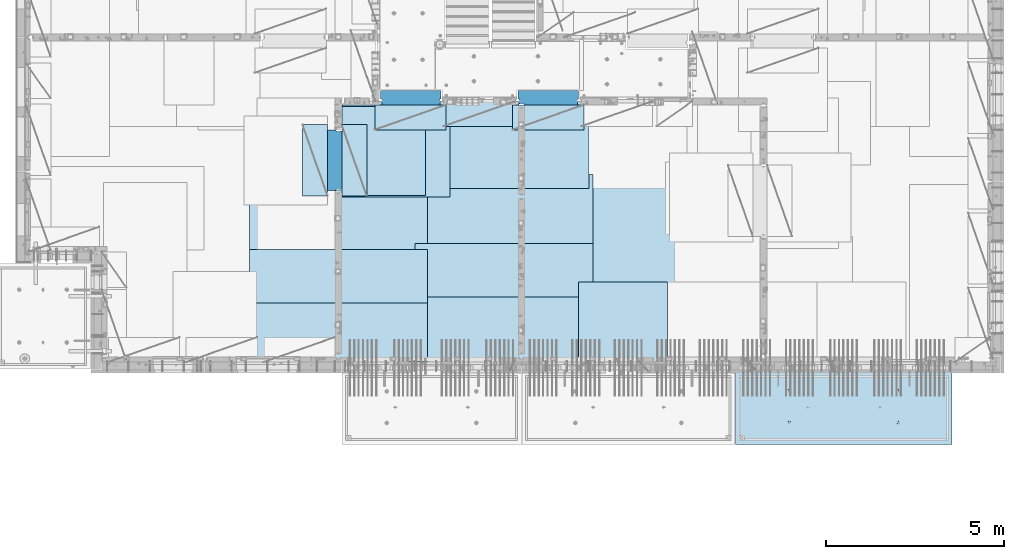
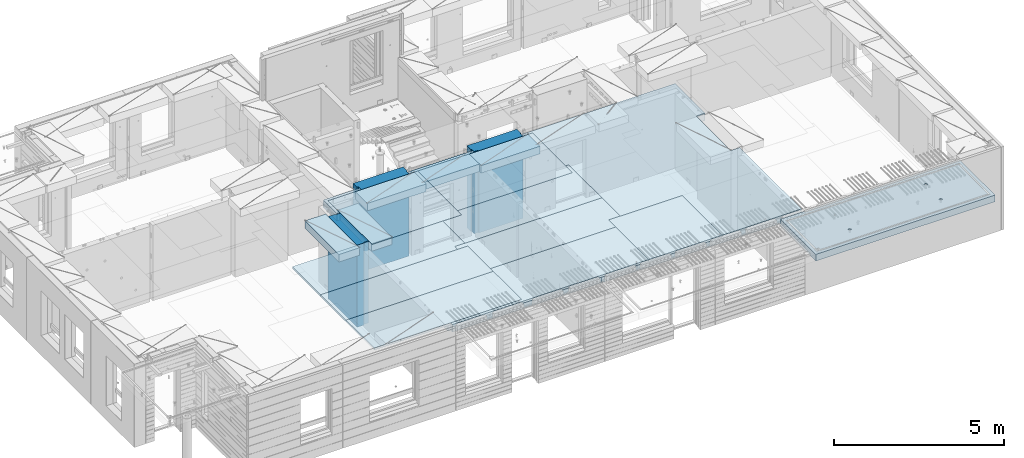
# One storey, part 203 of 349: 18 plates, 3 slabs, 19 elements without a shape of their own.
"""IFC2X3 building model written with IfcOpenShell, lengths in millimetres."""

from ifc_helpers import new_model, si_unit, frame, origin_with_axes, place, context, subcontext, project, spatial, faceted_brep, material, type_object, element, aggregate, save


model = new_model("IFC2X3")

# Units and contexts
model_context = context("Model", 3, precision=1e-05, world=origin_with_axes())
body_context = subcontext(model_context, "Body", "Model", "MODEL_VIEW")
ifc_project = project(units=[si_unit("LENGTHUNIT", "METRE", prefix="MILLI"), si_unit("AREAUNIT", "SQUARE_METRE"), si_unit("VOLUMEUNIT", "CUBIC_METRE"), si_unit("MASSUNIT", "GRAM", prefix="KILO"), si_unit("TIMEUNIT", "SECOND"), si_unit("PLANEANGLEUNIT", "RADIAN"), si_unit("SOLIDANGLEUNIT", "STERADIAN"), si_unit("THERMODYNAMICTEMPERATUREUNIT", "DEGREE_CELSIUS"), si_unit("LUMINOUSINTENSITYUNIT", "LUMEN")], contexts=[model_context])

# Site, building, storey
site_placement = place(None, origin_with_axes())
site = spatial("IfcSite", under=ifc_project, at=site_placement, CompositionType="ELEMENT")
building_placement = place(site_placement, origin_with_axes())
building = spatial("IfcBuilding", under=site, at=building_placement, CompositionType="ELEMENT")
storey_placement = place(building_placement, origin_with_axes())
storey = spatial("IfcBuildingStorey", under=building, at=storey_placement, Name="4", CompositionType="ELEMENT", Elevation=0.0)

# Assembly, slab
assembly_1_placement = place(storey_placement, origin_with_axes())
assembly_1 = element("IfcElementAssembly", 1, at=assembly_1_placement, inside=storey, AssemblyPlace="NOTDEFINED", PredefinedType="REINFORCEMENT_UNIT")
ifc_material_1 = material(Name="CONCRETE/C30/37")
slab_type_1 = type_object("IfcSlabType", PredefinedType="NOTDEFINED")
slab_1_placement = place(assembly_1_placement, frame((21810.0, 7750.0, 93595.0), z_axis=(0.0, 1.0, 0.0), x_axis=(1.0, 0.0, 0.0)))
slab_1 = element("IfcSlab", 2, at=slab_1_placement, type_object=slab_type_1, material=ifc_material_1, PredefinedType="FLOOR", context=body_context, shape_type="Brep", body=[
    faceted_brep([(6500.0, -135.0, 5637.99963378906), (6500.0, 135.0, 5637.99963378906), (6500.0, 135.0, 5680.0), (6500.0, -135.0, 5680.0), (6800.0, -135.0, 5680.0), (6800.0, 135.0, 5680.0), (6800.0, -135.0, 3637.99963378906), (6800.0, 135.0, 3637.99963378906), (6500.0, 135.0, 3637.99963378906), (6500.0, -135.0, 3637.99963378906), (6800.0, -135.0, 0.0), (6800.0, 135.0, 0.0), (1.81898940354586e-12, -135.0, 1.81898940354586e-12), (1.81898940354586e-12, 135.0, 1.81898940354586e-12), (0.0, -135.0, 7330.0), (0.0, 135.0, 7330.0), (1569.99914550782, -135.0, 7330.0), (1569.99914550782, 135.0, 7330.0), (1569.99914550782, -135.0, 7430.0), (1569.99914550782, 135.0, 7430.0), (6800.0, -135.0, 7430.0), (6800.0, 135.0, 7430.0), (6500.0, 135.0, 3780.0), (6500.0, -135.0, 3780.0)], [[[0, 1, 2, 3]], [[4, 3, 2, 5]], [[6, 7, 8, 9]], [[10, 11, 7, 6]], [[10, 12, 13, 11]], [[12, 14, 15, 13]], [[16, 17, 15, 14]], [[18, 19, 17, 16]], [[20, 21, 19, 18]], [[21, 20, 4, 5]], [[1, 22, 8, 7, 11, 13, 15, 17, 19, 21, 5, 2]], [[23, 9, 8, 22, 1, 0]], [[20, 18, 16, 14, 12, 10, 6, 9, 23, 0, 3, 4]]]),
])

assembly_2_placement = place(storey_placement, origin_with_axes())
assembly_2 = element("IfcElementAssembly", 3, at=assembly_2_placement, inside=storey, AssemblyPlace="NOTDEFINED", PredefinedType="REINFORCEMENT_UNIT")
ifc_material_2 = material(Name="CONCRETE/C35/45")
slab_type_2 = type_object("IfcSlabType", PredefinedType="NOTDEFINED")
slab_2_placement = place(assembly_2_placement, frame((33909.9998568133, 7629.99655735226, 93590.0), z_axis=(-1.11800000013248e-06, -0.999999999999375, 0.0), x_axis=(-0.999999999999093, 1.34699999998405e-06, 0.0)))
slab_2 = element("IfcSlab", 4, at=slab_2_placement, type_object=slab_type_2, material=ifc_material_2, PredefinedType="FLOOR", context=body_context, shape_type="Brep", body=[
    faceted_brep([(4605.44993885855, -113.0, 552.448239707288), (4619.38834372919, -113.0, 559.550231553701), (4630.44991833371, -113.0, 570.61183115741), (4637.55187867931, -113.0, 584.55025207851), (4639.99903540509, -113.0, 600.001104562554), (4637.55184376039, -113.0, 615.451951515985), (4630.44985191398, -113.0, 629.39035638662), (4619.38825231027, -113.0, 640.451930991143), (4605.44983138917, -113.0, 647.553891336743), (4589.99897890513, -113.0, 650.001048062522), (4574.54813195169, -113.0, 647.553856417822), (4560.60972708106, -113.0, 640.451864571409), (4549.54815247653, -113.0, 629.390264967699), (4542.44619213093, -113.0, 615.451844046599), (4539.99903540516, -113.0, 600.000991562554), (4542.44622704986, -113.0, 584.550144609124), (4549.54821889627, -113.0, 570.61173973849), (4560.60981849998, -113.0, 559.550165133966), (4574.54823942108, -113.0, 552.448204788368), (4589.99909190512, -113.0, 550.001048062586), (4548.90468317908, -120.0, 570.144182560607), (4541.68970509875, -120.0, 584.304334781456), (4560.14226277649, -120.0, 558.906628360102), (4574.30243130315, -120.0, 551.691682281732), (4589.99909280399, -120.0, 549.205593517132), (4605.69574868622, -120.0, 551.691717756181), (4619.85590090707, -120.0, 558.906695836513), (4631.09345510757, -120.0, 570.14427543392), (4638.30840118594, -120.0, 584.304443960583), (4640.79448995055, -120.0, 600.001105461418), (4638.30836571149, -120.0, 615.697761343653), (4631.09338763116, -120.0, 629.857913564502), (4619.85580803376, -120.0, 641.095467765007), (4605.6956395071, -120.0, 648.310413843377), (4589.99897800626, -120.0, 650.796502607977), (4574.30232212402, -120.0, 648.310378368928), (4560.14216990317, -120.0, 641.095400288596), (4548.90461570267, -120.0, 629.85782069119), (4541.6896696243, -120.0, 615.697652164527), (4539.2035808597, -120.0, 600.000990663691), (0.000819232023786753, -120.0, 2085.00366210938), (6090.0009765625, -120.0, 2085.00366210938), (6090.0009765625, 120.0, 2085.00366210938), (0.000819232023786753, 120.0, 2085.00366210938), (6090.0, -120.0, 1.39971234602854e-09), (6090.0, 120.0, 1.39971234602854e-09), (-7.27595761418343e-12, -120.0, -9.09494701772928e-13), (-7.27595761418343e-12, 120.0, -9.09494701772928e-13), (1515.44893888152, -108.0, 1437.45474794476), (1529.38734375216, -108.0, 1444.55673979117), (1540.44891835668, -108.0, 1455.61833939488), (1547.55087870228, -108.0, 1469.55676031598), (1549.99803542806, -108.0, 1485.00761280002), (1547.55084378336, -108.0, 1500.45845975345), (1540.44885193695, -108.0, 1514.39686462409), (1529.38725233324, -108.0, 1525.45843922861), (1515.44883141214, -108.0, 1532.56039957421), (1499.99797892809, -108.0, 1535.00755629999), (1484.54713197466, -108.0, 1532.56036465529), (1470.60872710403, -108.0, 1525.45837280888), (1459.5471524995, -108.0, 1514.39677320517), (1452.44519215391, -108.0, 1500.45835228407), (1449.99803542813, -108.0, 1485.00749980002), (1452.44522707283, -108.0, 1469.55665284659), (1459.54721891924, -108.0, 1455.61824797596), (1470.60881852295, -108.0, 1444.55667337144), (1484.54723944405, -108.0, 1437.45471302584), (1499.99809192809, -108.0, 1435.00755630005), (1451.1483322995, -120.0, 1469.13526457059), (1448.63439906449, -120.0, 1485.00749825911), (1458.44401483263, -120.0, 1454.8167213853), (1469.80729442553, -120.0, 1443.45346747338), (1484.12585409903, -120.0, 1436.15781730018), (1499.998093469, -120.0, 1433.64391993642), (1515.87032715753, -120.0, 1436.15785317143), (1530.18887034281, -120.0, 1443.45353570456), (1541.55212425473, -120.0, 1454.81681529746), (1548.84777442794, -120.0, 1469.13537497096), (1551.3616717917, -120.0, 1485.00761434093), (1548.84773855669, -120.0, 1500.87984802946), (1541.55205602355, -120.0, 1515.19839121474), (1530.18877643065, -120.0, 1526.56164512666), (1515.87021675716, -120.0, 1533.85729529987), (1499.99797738718, -120.0, 1536.37119266363), (1484.12574369866, -120.0, 1533.85725942862), (1469.80720051337, -120.0, 1526.56157689548), (1458.44394660145, -120.0, 1515.19829730258), (1451.14829642824, -120.0, 1500.87973762909), (1515.44993893152, -113.0, 552.45474794532), (1529.38834380215, -113.0, 559.556739791733), (1540.44991840668, -113.0, 570.618339395443), (1547.55187875228, -113.0, 584.556760316543), (1549.99903547806, -113.0, 600.007612800588), (1547.55184383336, -113.0, 615.458459754018), (1540.44985198694, -113.0, 629.396864624653), (1529.38825238323, -113.0, 640.458439229175), (1515.44983146213, -113.0, 647.560399574775), (1499.99897897809, -113.0, 650.007556300556), (1484.54813202466, -113.0, 647.560364655855), (1470.60972715402, -113.0, 640.458372809442), (1459.5481525495, -113.0, 629.396773205733), (1452.4461922039, -113.0, 615.458352284632), (1449.99903547812, -113.0, 600.007499800588), (1452.44622712283, -113.0, 584.556652847157), (1459.54821896923, -113.0, 570.618247976523), (1470.60981857295, -113.0, 559.556673372), (1484.54823949404, -113.0, 552.4547130264), (1499.99909197809, -113.0, 550.007556300619), (1451.68970517172, -120.0, 584.310843019489), (1449.20358093267, -120.0, 600.007498901724), (1458.90468325205, -120.0, 570.15069079864), (1470.14226284945, -120.0, 558.913136598135), (1484.30243137612, -120.0, 551.698190519764), (1499.99909287695, -120.0, 549.212101755165), (1515.69574875919, -120.0, 551.698225994213), (1529.85590098004, -120.0, 558.913204074546), (1541.09345518054, -120.0, 570.150783671952), (1548.30840125891, -120.0, 584.310952198615), (1550.79449002351, -120.0, 600.007613699451), (1548.30836578447, -120.0, 615.704269581685), (1541.09338770413, -120.0, 629.864421802535), (1529.85580810672, -120.0, 641.10197600304), (1515.69563958006, -120.0, 648.31692208141), (1499.99897807923, -120.0, 650.803010846011), (1484.30232219699, -120.0, 648.316886606961), (1470.14216997614, -120.0, 641.101908526629), (1458.90461577564, -120.0, 629.864328929222), (1451.68966969727, -120.0, 615.704160402559), (4605.44893880856, -108.0, 1437.44823970672), (4619.38734367919, -108.0, 1444.55023155314), (4630.44891828372, -108.0, 1455.61183115685), (4637.55087862931, -108.0, 1469.55025207795), (4639.99803535509, -108.0, 1485.00110456199), (4637.55084371039, -108.0, 1500.45195151542), (4630.44885186398, -108.0, 1514.39035638605), (4619.38725226027, -108.0, 1525.45193099058), (4605.44883133917, -108.0, 1532.55389133618), (4589.99797885512, -108.0, 1535.00104806196), (4574.54713190169, -108.0, 1532.55385641726), (4560.60872703106, -108.0, 1525.45186457084), (4549.54715242653, -108.0, 1514.39026496713), (4542.44519208094, -108.0, 1500.45184404603), (4539.99803535516, -108.0, 1485.00099156199), (4542.44522699986, -108.0, 1469.55014460856), (4549.54721884627, -108.0, 1455.61173973792), (4560.60881844998, -108.0, 1444.5501651334), (4574.54723937108, -108.0, 1437.4482047878), (4589.99809185513, -108.0, 1435.00104806202), (4541.14833222653, -120.0, 1469.12875633256), (4538.63439899152, -120.0, 1485.00099002108), (4548.44401475967, -120.0, 1454.81021314727), (4559.80729435257, -120.0, 1443.44695923535), (4574.12585402606, -120.0, 1436.15130906214), (4589.99809339604, -120.0, 1433.63741169839), (4605.87032708456, -120.0, 1436.1513449334), (4620.18887026985, -120.0, 1443.44702746653), (4631.55212418177, -120.0, 1454.81030705943), (4638.84777435497, -120.0, 1469.12886673293), (4641.36167171873, -120.0, 1485.0011061029), (4638.84773848372, -120.0, 1500.87333979142), (4631.55205595059, -120.0, 1515.19188297671), (4620.18877635769, -120.0, 1526.55513688863), (4605.87021668419, -120.0, 1533.85078706184), (4589.99797731422, -120.0, 1536.36468442559), (4574.12574362569, -120.0, 1533.85075119058), (4559.80720044041, -120.0, 1526.55506865745), (4548.44394652849, -120.0, 1515.19178906455), (4541.14829635528, -120.0, 1500.87322939105)], [[[0, 1, 2, 3, 4, 5, 6, 7, 8, 9, 10, 11, 12, 13, 14, 15, 16, 17, 18, 19]], [[20, 16, 15, 21]], [[22, 17, 16, 20]], [[23, 18, 17, 22]], [[24, 19, 18, 23]], [[25, 0, 19, 24]], [[26, 1, 0, 25]], [[27, 2, 1, 26]], [[28, 3, 2, 27]], [[29, 4, 3, 28]], [[30, 5, 4, 29]], [[31, 6, 5, 30]], [[32, 7, 6, 31]], [[33, 8, 7, 32]], [[34, 9, 8, 33]], [[35, 10, 9, 34]], [[36, 11, 10, 35]], [[37, 12, 11, 36]], [[38, 13, 12, 37]], [[39, 14, 13, 38]], [[21, 15, 14, 39]], [[40, 41, 42, 43]], [[41, 44, 45, 42]], [[44, 46, 47, 45]], [[42, 45, 47, 43]], [[46, 40, 43, 47]], [[48, 49, 50, 51, 52, 53, 54, 55, 56, 57, 58, 59, 60, 61, 62, 63, 64, 65, 66, 67]], [[68, 63, 62, 69]], [[70, 64, 63, 68]], [[71, 65, 64, 70]], [[72, 66, 65, 71]], [[73, 67, 66, 72]], [[74, 48, 67, 73]], [[75, 49, 48, 74]], [[76, 50, 49, 75]], [[77, 51, 50, 76]], [[78, 52, 51, 77]], [[79, 53, 52, 78]], [[80, 54, 53, 79]], [[81, 55, 54, 80]], [[82, 56, 55, 81]], [[83, 57, 56, 82]], [[84, 58, 57, 83]], [[85, 59, 58, 84]], [[86, 60, 59, 85]], [[87, 61, 60, 86]], [[69, 62, 61, 87]], [[88, 89, 90, 91, 92, 93, 94, 95, 96, 97, 98, 99, 100, 101, 102, 103, 104, 105, 106, 107]], [[108, 103, 102, 109]], [[110, 104, 103, 108]], [[111, 105, 104, 110]], [[112, 106, 105, 111]], [[113, 107, 106, 112]], [[114, 88, 107, 113]], [[115, 89, 88, 114]], [[116, 90, 89, 115]], [[117, 91, 90, 116]], [[118, 92, 91, 117]], [[119, 93, 92, 118]], [[120, 94, 93, 119]], [[121, 95, 94, 120]], [[122, 96, 95, 121]], [[123, 97, 96, 122]], [[124, 98, 97, 123]], [[125, 99, 98, 124]], [[126, 100, 99, 125]], [[127, 101, 100, 126]], [[109, 102, 101, 127]], [[128, 129, 130, 131, 132, 133, 134, 135, 136, 137, 138, 139, 140, 141, 142, 143, 144, 145, 146, 147]], [[148, 143, 142, 149]], [[150, 144, 143, 148]], [[151, 145, 144, 150]], [[152, 146, 145, 151]], [[153, 147, 146, 152]], [[154, 128, 147, 153]], [[155, 129, 128, 154]], [[156, 130, 129, 155]], [[157, 131, 130, 156]], [[158, 132, 131, 157]], [[159, 133, 132, 158]], [[160, 134, 133, 159]], [[161, 135, 134, 160]], [[162, 136, 135, 161]], [[163, 137, 136, 162]], [[164, 138, 137, 163]], [[165, 139, 138, 164]], [[166, 140, 139, 165]], [[167, 141, 140, 166]], [[149, 142, 141, 167]], [[44, 41, 40, 46], [37, 36, 35, 34, 33, 32, 31, 30, 29, 28, 27, 26, 25, 24, 23, 22, 20, 21, 39, 38], [166, 165, 164, 163, 162, 161, 160, 159, 158, 157, 156, 155, 154, 153, 152, 151, 150, 148, 149, 167], [126, 125, 124, 123, 122, 121, 120, 119, 118, 117, 116, 115, 114, 113, 112, 111, 110, 108, 109, 127], [86, 85, 84, 83, 82, 81, 80, 79, 78, 77, 76, 75, 74, 73, 72, 71, 70, 68, 69, 87]]]),
])
aggregate(assembly_2, [slab_2])

# Assembly, plate
assembly_3_placement = place(storey_placement, origin_with_axes())
assembly_3 = element("IfcElementAssembly", 5, at=assembly_3_placement, inside=storey, Name="Steel Assembly", AssemblyPlace="NOTDEFINED", PredefinedType="NOTDEFINED")
ifc_material_3 = material()
plate_type_1 = type_object("IfcPlateType", PredefinedType="NOTDEFINED")
plate_1_placement = place(assembly_3_placement, frame((25910.0, 7750.0, 93695.1), z_axis=(-1.0, 3.00000001838171e-08, 0.0), x_axis=(0.0, 1.0, 0.0)))
plate_1 = element("IfcPlate", 6, at=plate_1_placement, type_object=plate_type_1, material=ifc_material_3, Name="1/2", context=body_context, shape_type="Brep", body=[
    faceted_brep([(0.0, -35.0, 0.0), (0.0, -35.0, 2500.0), (0.0, 35.0, 2500.0), (0.0, 35.0, 0.0), (2349.99951171875, -35.0, 2500.0), (2349.99951171875, 35.0, 2500.0), (2350.0, -35.0, 0.0), (2350.0, 35.0, 0.0)], [[[0, 1, 2, 3]], [[1, 4, 5, 2]], [[4, 6, 7, 5]], [[6, 0, 3, 7]], [[5, 7, 3, 2]], [[6, 4, 1, 0]]]),
])
aggregate(assembly_3, [plate_1])

assembly_4_placement = place(storey_placement, origin_with_axes())
assembly_4 = element("IfcElementAssembly", 7, at=assembly_4_placement, inside=storey, Name="Steel Assembly", AssemblyPlace="NOTDEFINED", PredefinedType="NOTDEFINED")
plate_2_placement = place(assembly_4_placement, frame((16759.9995320312, 12530.0000289158, 93695.1), z_axis=(0.0, 1.0, 0.0), x_axis=(1.0, 0.0, 0.0)))
plate_2 = element("IfcPlate", 8, at=plate_2_placement, type_object=plate_type_1, material=ifc_material_3, Name="1/2", context=body_context, shape_type="Brep", body=[
    faceted_brep([(0.0, -35.0, 0.0), (0.0, -35.0, 2500.0), (0.0, 35.0, 2500.0), (0.0, 35.0, 0.0), (2349.99951171875, -35.0, 2500.0), (2349.99951171875, 35.0, 2500.0), (2350.0, -35.0, 0.0), (2350.0, 35.0, 0.0)], [[[0, 1, 2, 3]], [[1, 4, 5, 2]], [[4, 6, 7, 5]], [[6, 0, 3, 7]], [[5, 7, 3, 2]], [[6, 4, 1, 0]]]),
])
aggregate(assembly_4, [plate_2])

assembly_5_placement = place(storey_placement, origin_with_axes())
assembly_5 = element("IfcElementAssembly", 9, at=assembly_5_placement, inside=storey, Name="Steel Assembly", AssemblyPlace="NOTDEFINED", PredefinedType="NOTDEFINED")
plate_3_placement = place(assembly_5_placement, frame((23810.0, 10780.0, 93695.1), z_axis=(-1.0, 3.00000001838171e-08, 0.0), x_axis=(0.0, 1.0, 0.0)))
plate_3 = element("IfcPlate", 10, at=plate_3_placement, type_object=plate_type_1, material=ifc_material_3, context=body_context, shape_type="Brep", body=[
    faceted_brep([(0.0, -35.0, 0.0), (0.0, -35.0, 5000.0), (0.0, 35.0, 5000.0), (0.0, 35.0, 0.0), (2349.99951171875, -35.0, 5000.0), (2349.99951171875, 35.0, 5000.0), (2350.0, -35.0, 0.0), (2350.0, 35.0, 0.0)], [[[0, 1, 2, 3]], [[1, 4, 5, 2]], [[4, 6, 7, 5]], [[6, 0, 3, 7]], [[5, 7, 3, 2]], [[6, 4, 1, 0]]]),
])
aggregate(assembly_5, [plate_3])

assembly_6_placement = place(storey_placement, origin_with_axes())
assembly_6 = element("IfcElementAssembly", 11, at=assembly_6_placement, inside=storey, Name="Steel Assembly", AssemblyPlace="NOTDEFINED", PredefinedType="NOTDEFINED")
plate_4_placement = place(assembly_6_placement, frame((23710.0, 12730.0, 93695.1), z_axis=(-1.0, 3.00000001838171e-08, 0.0), x_axis=(0.0, 1.0, 0.0)))
plate_4 = element("IfcPlate", 12, at=plate_4_placement, type_object=plate_type_1, material=ifc_material_3, context=body_context, shape_type="Brep", body=[
    faceted_brep([(0.0, -35.0, 0.0), (0.0, -35.0, 5000.0), (0.0, 35.0, 5000.0), (0.0, 35.0, 0.0), (2349.99951171875, -35.0, 5000.0), (2349.99951171875, 35.0, 5000.0), (2350.0, -35.0, 0.0), (2350.0, 35.0, 0.0)], [[[0, 1, 2, 3]], [[1, 4, 5, 2]], [[4, 6, 7, 5]], [[6, 0, 3, 7]], [[5, 7, 3, 2]], [[6, 4, 1, 0]]]),
])
aggregate(assembly_6, [plate_4])

assembly_7_placement = place(storey_placement, origin_with_axes())
assembly_7 = element("IfcElementAssembly", 13, at=assembly_7_placement, inside=storey, Name="Steel Assembly", AssemblyPlace="NOTDEFINED", PredefinedType="NOTDEFINED")
plate_5_placement = place(assembly_7_placement, frame((23810.0, 7750.0, 93695.1), z_axis=(-1.0, 3.00000001838171e-08, 0.0), x_axis=(0.0, 1.0, 0.0)))
plate_5 = element("IfcPlate", 14, at=plate_5_placement, type_object=plate_type_1, material=ifc_material_3, context=body_context, shape_type="Brep", body=[
    faceted_brep([(0.0, -35.0, 0.0), (0.0, -35.0, 5000.0), (0.0, 35.0, 5000.0), (0.0, 35.0, 0.0), (2349.99951171875, -35.0, 5000.0), (2349.99951171875, 35.0, 5000.0), (2350.0, -35.0, 0.0), (2350.0, 35.0, 0.0)], [[[0, 1, 2, 3]], [[1, 4, 5, 2]], [[4, 6, 7, 5]], [[6, 0, 3, 7]], [[5, 7, 3, 2]], [[6, 4, 1, 0]]]),
])
aggregate(assembly_7, [plate_5])

assembly_8_placement = place(storey_placement, origin_with_axes())
assembly_8 = element("IfcElementAssembly", 15, at=assembly_8_placement, inside=storey, Name="Steel Assembly", AssemblyPlace="NOTDEFINED", PredefinedType="NOTDEFINED")
plate_6_placement = place(assembly_8_placement, frame((19160.0, 10325.0, 93695.1), z_axis=(-1.0, 3.00000001838171e-08, 0.0), x_axis=(0.0, 1.0, 0.0)))
plate_6 = element("IfcPlate", 16, at=plate_6_placement, type_object=plate_type_1, material=ifc_material_3, context=body_context, shape_type="Brep", body=[
    faceted_brep([(0.0, -35.0, 0.0), (0.0, -35.0, 5000.0), (0.0, 35.0, 5000.0), (0.0, 35.0, 0.0), (2349.99951171875, -35.0, 5000.0), (2349.99951171875, 35.0, 5000.0), (2350.0, -35.0, 0.0), (2350.0, 35.0, 0.0)], [[[0, 1, 2, 3]], [[1, 4, 5, 2]], [[4, 6, 7, 5]], [[6, 0, 3, 7]], [[5, 7, 3, 2]], [[6, 4, 1, 0]]]),
])
aggregate(assembly_8, [plate_6])

assembly_9_placement = place(storey_placement, origin_with_axes())
assembly_9 = element("IfcElementAssembly", 17, at=assembly_9_placement, inside=storey, Name="Steel Assembly", AssemblyPlace="NOTDEFINED", PredefinedType="NOTDEFINED")
plate_7_placement = place(assembly_9_placement, frame((19160.0, 7850.0, 93695.1), z_axis=(-1.0, 3.00000001838171e-08, 0.0), x_axis=(0.0, 1.0, 0.0)))
plate_7 = element("IfcPlate", 18, at=plate_7_placement, type_object=plate_type_1, material=ifc_material_3, context=body_context, shape_type="Brep", body=[
    faceted_brep([(0.0, -35.0, 0.0), (0.0, -35.0, 5000.0), (0.0, 35.0, 5000.0), (0.0, 35.0, 0.0), (2349.99951171875, -35.0, 5000.0), (2349.99951171875, 35.0, 5000.0), (2350.0, -35.0, 0.0), (2350.0, 35.0, 0.0)], [[[0, 1, 2, 3]], [[1, 4, 5, 2]], [[4, 6, 7, 5]], [[6, 0, 3, 7]], [[5, 7, 3, 2]], [[6, 4, 1, 0]]]),
])
aggregate(assembly_9, [plate_7])

assembly_10_placement = place(storey_placement, origin_with_axes())
assembly_10 = element("IfcElementAssembly", 19, at=assembly_10_placement, inside=storey, Name="Steel Assembly", AssemblyPlace="NOTDEFINED", PredefinedType="NOTDEFINED")
plate_type_2 = type_object("IfcPlateType", PredefinedType="NOTDEFINED")
plate_8_placement = place(assembly_10_placement, frame((18810.0, 11180.0000122641, 93695.1000003815), z_axis=(1.0, 0.0, 0.0), x_axis=(0.0, -1.0, 0.0)))
plate_8 = element("IfcPlate", 20, at=plate_8_placement, type_object=plate_type_2, material=ifc_material_3, context=body_context, shape_type="Brep", body=[
    faceted_brep([(0.0, -35.0, 0.0), (0.0, -35.0, 5000.0), (0.0, 35.0, 5000.0), (0.0, 35.0, 0.0), (1499.99951171875, -35.0, 5000.0), (1499.99951171875, 35.0, 5000.0), (1500.0, -35.0, 0.0), (1500.0, 35.0, 0.0)], [[[0, 1, 2, 3]], [[1, 4, 5, 2]], [[4, 6, 7, 5]], [[6, 0, 3, 7]], [[5, 7, 3, 2]], [[6, 4, 1, 0]]]),
])
aggregate(assembly_10, [plate_8])

assembly_11_placement = place(storey_placement, origin_with_axes())
assembly_11 = element("IfcElementAssembly", 21, at=assembly_11_placement, inside=storey, Name="Steel Assembly", AssemblyPlace="NOTDEFINED", PredefinedType="NOTDEFINED")
plate_9_placement = place(assembly_11_placement, frame((14160.0, 11015.0000122641, 93695.1000003815), z_axis=(1.0, 0.0, 0.0), x_axis=(0.0, -1.0, 0.0)))
plate_9 = element("IfcPlate", 22, at=plate_9_placement, type_object=plate_type_2, material=ifc_material_3, context=body_context, shape_type="Brep", body=[
    faceted_brep([(0.0, -35.0, 0.0), (0.0, -35.0, 5000.0), (0.0, 35.0, 5000.0), (0.0, 35.0, 0.0), (1499.99951171875, -35.0, 5000.0), (1499.99951171875, 35.0, 5000.0), (1500.0, -35.0, 0.0), (1500.0, 35.0, 0.0)], [[[0, 1, 2, 3]], [[1, 4, 5, 2]], [[4, 6, 7, 5]], [[6, 0, 3, 7]], [[5, 7, 3, 2]], [[6, 4, 1, 0]]]),
])
aggregate(assembly_11, [plate_9])

assembly_12_placement = place(storey_placement, origin_with_axes())
assembly_12 = element("IfcElementAssembly", 23, at=assembly_12_placement, inside=storey, Name="Steel Assembly", AssemblyPlace="NOTDEFINED", PredefinedType="NOTDEFINED")
plate_type_3 = type_object("IfcPlateType", PredefinedType="NOTDEFINED")
plate_10_placement = place(assembly_12_placement, frame((16759.9998779297, 14525.0, 93595.3), z_axis=(1.0, 0.0, 0.0), x_axis=(0.0, -1.0, 0.0)))
plate_10 = element("IfcPlate", 24, at=plate_10_placement, type_object=plate_type_3, material=ifc_material_3, Name="RE1", context=body_context, shape_type="Brep", body=[
    faceted_brep([(1.81898940354586e-12, -135.0, 1.81898940354586e-12), (0.0, -135.0, 699.999999999996), (0.0, 135.0, 699.999999999996), (1.81898940354586e-12, 135.0, 1.81898940354586e-12), (1999.99951171875, -135.0, 699.999999999993), (1999.99951171875, 135.0, 699.999999999993), (2000.0, -135.0, -3.63797880709171e-12), (2000.0, 135.0, -3.63797880709171e-12)], [[[0, 1, 2, 3]], [[1, 4, 5, 2]], [[4, 6, 7, 5]], [[6, 0, 3, 7]], [[5, 7, 3, 2]], [[6, 4, 1, 0]]]),
])
aggregate(assembly_12, [plate_10])

assembly_13_placement = place(storey_placement, origin_with_axes())
assembly_13 = element("IfcElementAssembly", 25, at=assembly_13_placement, inside=storey, Name="Steel Assembly", AssemblyPlace="NOTDEFINED", PredefinedType="NOTDEFINED")
plate_11_placement = place(assembly_13_placement, frame((16359.7701220703, 12525.0, 93595.3), z_axis=(-1.0, 3.00000001838171e-08, 0.0), x_axis=(0.0, 1.0, 0.0)))
plate_11 = element("IfcPlate", 26, at=plate_11_placement, type_object=plate_type_3, material=ifc_material_3, Name="RE1", context=body_context, shape_type="Brep", body=[
    faceted_brep([(1.81898940354586e-12, -135.0, 1.81898940354586e-12), (0.0, -135.0, 699.999999999996), (0.0, 135.0, 699.999999999996), (1.81898940354586e-12, 135.0, 1.81898940354586e-12), (1999.99951171875, -135.0, 699.999999999993), (1999.99951171875, 135.0, 699.999999999993), (2000.0, -135.0, -3.63797880709171e-12), (2000.0, 135.0, -3.63797880709171e-12)], [[[0, 1, 2, 3]], [[1, 4, 5, 2]], [[4, 6, 7, 5]], [[6, 0, 3, 7]], [[5, 7, 3, 2]], [[6, 4, 1, 0]]]),
])
aggregate(assembly_13, [plate_11])

assembly_14_placement = place(storey_placement, origin_with_axes())
assembly_14 = element("IfcElementAssembly", 27, at=assembly_14_placement, inside=storey, Name="Steel Assembly", AssemblyPlace="NOTDEFINED", PredefinedType="NOTDEFINED")
plate_12_placement = place(assembly_14_placement, frame((21624.9991457614, 15179.9998963664, 93595.3), z_axis=(0.0, -1.0, 0.0), x_axis=(-1.0, 3.00000001838171e-08, 0.0)))
plate_12 = element("IfcPlate", 28, at=plate_12_placement, type_object=plate_type_3, material=ifc_material_3, Name="RE1", context=body_context, shape_type="Brep", body=[
    faceted_brep([(1.81898940354586e-12, -135.0, 1.81898940354586e-12), (0.0, -135.0, 699.999999999996), (0.0, 135.0, 699.999999999996), (1.81898940354586e-12, 135.0, 1.81898940354586e-12), (1999.99951171875, -135.0, 699.999999999993), (1999.99951171875, 135.0, 699.999999999993), (2000.0, -135.0, -3.63797880709171e-12), (2000.0, 135.0, -3.63797880709171e-12)], [[[0, 1, 2, 3]], [[1, 4, 5, 2]], [[4, 6, 7, 5]], [[6, 0, 3, 7]], [[5, 7, 3, 2]], [[6, 4, 1, 0]]]),
])
aggregate(assembly_14, [plate_12])

assembly_15_placement = place(storey_placement, origin_with_axes())
assembly_15 = element("IfcElementAssembly", 29, at=assembly_15_placement, inside=storey, Name="Steel Assembly", AssemblyPlace="NOTDEFINED", PredefinedType="NOTDEFINED")
plate_13_placement = place(assembly_15_placement, frame((23559.9991457614, 15079.9998963664, 93595.3), z_axis=(0.0, -1.0, 0.0), x_axis=(-1.0, 3.00000001838171e-08, 0.0)))
plate_13 = element("IfcPlate", 30, at=plate_13_placement, type_object=plate_type_3, material=ifc_material_3, Name="RE1", context=body_context, shape_type="Brep", body=[
    faceted_brep([(1.81898940354586e-12, -135.0, 1.81898940354586e-12), (0.0, -135.0, 699.999999999996), (0.0, 135.0, 699.999999999996), (1.81898940354586e-12, 135.0, 1.81898940354586e-12), (1999.99951171875, -135.0, 699.999999999993), (1999.99951171875, 135.0, 699.999999999993), (2000.0, -135.0, -3.63797880709171e-12), (2000.0, 135.0, -3.63797880709171e-12)], [[[0, 1, 2, 3]], [[1, 4, 5, 2]], [[4, 6, 7, 5]], [[6, 0, 3, 7]], [[5, 7, 3, 2]], [[6, 4, 1, 0]]]),
])
aggregate(assembly_15, [plate_13])

assembly_16_placement = place(storey_placement, origin_with_axes())
assembly_16 = element("IfcElementAssembly", 31, at=assembly_16_placement, inside=storey, Name="Steel Assembly", AssemblyPlace="NOTDEFINED", PredefinedType="NOTDEFINED")
plate_14_placement = place(assembly_16_placement, frame((19689.9991457614, 15079.9998963664, 93595.3), z_axis=(0.0, -1.0, 0.0), x_axis=(-1.0, 3.00000001838171e-08, 0.0)))
plate_14 = element("IfcPlate", 32, at=plate_14_placement, type_object=plate_type_3, material=ifc_material_3, Name="RE1", context=body_context, shape_type="Brep", body=[
    faceted_brep([(1.81898940354586e-12, -135.0, 1.81898940354586e-12), (0.0, -135.0, 699.999999999996), (0.0, 135.0, 699.999999999996), (1.81898940354586e-12, 135.0, 1.81898940354586e-12), (1999.99951171875, -135.0, 699.999999999993), (1999.99951171875, 135.0, 699.999999999993), (2000.0, -135.0, -3.63797880709171e-12), (2000.0, 135.0, -3.63797880709171e-12)], [[[0, 1, 2, 3]], [[1, 4, 5, 2]], [[4, 6, 7, 5]], [[6, 0, 3, 7]], [[5, 7, 3, 2]], [[6, 4, 1, 0]]]),
])
aggregate(assembly_16, [plate_14])

# Plate
plate_type_4 = type_object("IfcPlateType", PredefinedType="NOTDEFINED")
plate_15_placement = place(assembly_1_placement, frame((16760.0002457424, 12487.9997681111, 93725.45), z_axis=(0.0, 1.0, 0.0), x_axis=(1.0, 0.0, 0.0)))
plate_15 = element("IfcPlate", 33, at=plate_15_placement, type_object=plate_type_4, material=ifc_material_3, context=body_context, shape_type="Brep", body=[
    faceted_brep([(0.0, -5.0, 0.0), (0.0, -5.0, 2592.0), (0.0, 5.0, 2592.0), (0.0, 5.0, 0.0), (3041.99975585938, -5.0, 2592.0), (3041.99975585938, 5.0, 2592.0), (3041.99975585938, -5.0, 0.0), (3041.99975585938, 5.0, 0.0)], [[[0, 1, 2, 3]], [[1, 4, 5, 2]], [[4, 6, 7, 5]], [[6, 0, 3, 7]], [[5, 7, 3, 2]], [[6, 4, 1, 0]]]),
])

# Slab
slab_type_3 = type_object("IfcSlabType", PredefinedType="NOTDEFINED")
slab_3_placement = place(assembly_1_placement, frame((21810.0, 15180.0, 93595.0), z_axis=(0.0, -1.0, 0.0), x_axis=(-1.0, 3.00000001838171e-08, 0.0)))
slab_3 = element("IfcSlab", 34, at=slab_3_placement, type_object=slab_type_3, material=ifc_material_1, PredefinedType="FLOOR", context=body_context, shape_type="Brep", body=[
    faceted_brep([(2300.00087620694, -135.0, -2.78342304227408e-06), (2300.00087620694, 135.0, 0.0), (2300.00087620694, 135.0, 100.000233727807), (2300.00087620694, -135.0, 100.000233727807), (3920.000509996, 135.000000000015, 100.000233727807), (3920.000509996, -135.0, 100.000233727807), (3920.00085449219, -135.0, 0.0), (3920.00085449219, 135.0, 0.0), (5150.0, 135.0, 0.0), (5150.0, -135.0, 0.0), (5150.0, 135.0, 804.999923541527), (5150.0, -135.0, 804.999923541527), (5049.99975425761, 135.0, 804.999923541527), (5049.99975425761, -135.0, 804.999923541527), (5049.99975425761, 135.0, 2504.99992354153), (5049.99975425761, -135.0, 2504.99992354153), (5150.0, 135.0, 2504.99992354153), (5150.0, -135.0, 2504.99992354153), (5150.0, 135.0, 7330.0), (5150.0, -135.0, 7330.0), (5055.0, -135.0, 7330.0), (5055.0, 135.0, 7330.0), (5055.0, -135.0, 7430.0), (5055.0, 135.0, 7430.0), (0.0, -135.0, 7430.0), (0.0, 135.0, 7430.0), (70.0000000000036, -135.0, -8.47121555125341e-08), (3.63797880709171e-12, -135.0, 100.0), (70.0000000000036, -135.000000000015, 100.0), (70.0000000000036, 135.0, 0.0), (70.0000000000036, 135.0, 100.0), (0.0, 135.0, 100.0)], [[[0, 1, 2, 3]], [[3, 2, 4, 5]], [[6, 5, 4, 7]], [[8, 9, 6, 7]], [[9, 8, 10, 11]], [[11, 10, 12, 13]], [[13, 12, 14, 15]], [[15, 14, 16, 17]], [[18, 19, 17, 16]], [[20, 19, 18, 21]], [[22, 20, 21, 23]], [[24, 22, 23, 25]], [[26, 0, 3, 5, 6, 9, 11, 13, 15, 17, 19, 20, 22, 24, 27, 28]], [[1, 0, 26, 29]], [[25, 23, 21, 18, 16, 14, 12, 10, 8, 7, 4, 2, 1, 29, 30, 31]], [[26, 28, 30, 29]], [[27, 31, 30, 28]], [[24, 25, 31, 27]]]),
])

aggregate(assembly_1, [plate_15, slab_3, slab_1])

# Assembly, plate
assembly_17_placement = place(storey_placement, origin_with_axes())
assembly_17 = element("IfcElementAssembly", 35, at=assembly_17_placement, inside=storey, Name="Steel Assembly", AssemblyPlace="NOTDEFINED", PredefinedType="NOTDEFINED")
ifc_material_4 = material()
plate_type_5 = type_object("IfcPlateType", PredefinedType="NOTDEFINED")
plate_16_placement = place(assembly_17_placement, frame((17840.0, 15080.0, 92255.6000003815), z_axis=(0.0, 1.0, 0.0), x_axis=(1.0, 0.0, 0.0)))
plate_16 = element("IfcPlate", 36, at=plate_16_placement, type_object=plate_type_5, material=ifc_material_4, context=body_context, shape_type="Brep", body=[
    faceted_brep([(49.9991463160914, -1475.0, 156.999999814216), (49.9991455078125, -1216.89999961853, 156.999999999998), (49.9994900039455, -1216.89999961853, -0.000233727812883444), (49.9994832763732, -1475.0, 0.0), (0.0, -1475.0, 170.000000230655), (-0.00085392879191204, -1216.89999961853, 170.000000368096), (0.0, -1475.0, 400.0), (1699.99914550781, -1475.0, 400.0), (1699.99914550781, 1475.0, 400.0), (0.0, 1475.0, 400.0), (1699.99914550781, -1475.0, 169.999999999998), (1699.99914550781, 1475.0, 169.999999999998), (1669.99914550781, 1475.0, 156.999999999998), (1669.99914550781, 1475.0, 3.63797880709171e-12), (49.9994900039455, 1475.0, 0.0), (49.9991455078125, 1475.0, 156.999999999998), (0.0, 1475.0, 170.000000368096), (1669.99914550781, -1475.0, 156.999999999998), (1669.99914550781, -1475.0, 3.63797880709171e-12)], [[[0, 1, 2, 3]], [[4, 5, 1, 0]], [[6, 7, 8, 9]], [[8, 7, 10, 11]], [[9, 8, 11, 12, 13, 14, 15, 16]], [[10, 17, 12, 11]], [[18, 13, 12, 17]], [[14, 13, 18, 3, 2]], [[14, 2, 1, 15]], [[15, 1, 5, 16]], [[6, 9, 16, 5, 4]], [[18, 17, 10, 7, 6, 4, 0, 3]]]),
])
aggregate(assembly_17, [plate_16])

assembly_18_placement = place(storey_placement, origin_with_axes())
assembly_18 = element("IfcElementAssembly", 37, at=assembly_18_placement, inside=storey, Name="Steel Assembly", AssemblyPlace="NOTDEFINED", PredefinedType="NOTDEFINED")
plate_17_placement = place(assembly_18_placement, frame((21710.0, 15080.0, 92255.6000003815), z_axis=(0.0, 1.0, 0.0), x_axis=(1.0, 0.0, 0.0)))
plate_17 = element("IfcPlate", 38, at=plate_17_placement, type_object=plate_type_5, material=ifc_material_4, context=body_context, shape_type="Brep", body=[
    faceted_brep([(30.0, -1475.0, 29.9998239177003), (30.0, 1475.0, 29.9998239177003), (157.0, 1475.0, 29.9998239177003), (157.0, -1475.0, 29.9998239177003), (169.999923697669, -1475.0, 0.0), (169.999923697669, 1475.0, 0.0), (0.0, -1475.0, 170.000000230655), (0.0, 1475.0, 170.000000368096), (30.0, 1475.0, 156.999999999998), (30.0, -1475.0, 156.999999999998), (0.0, -1475.0, 400.0), (0.0, 1475.0, 400.0), (1699.99914550781, -1475.0, 400.0), (1699.99914550781, 1475.0, 400.0), (1699.99914550781, -1475.0, 169.999999999998), (1699.99914550781, 1475.0, 169.999999999998), (1669.99914550781, -1475.0, 156.999999999998), (1669.99914550781, 1475.0, 156.999999999998), (1669.99914550781, -1475.0, 3.63797880709171e-12), (1669.99914550781, 1475.0, 3.63797880709171e-12)], [[[0, 1, 2, 3]], [[4, 3, 2, 5]], [[6, 7, 8, 9]], [[10, 11, 7, 6]], [[10, 12, 13, 11]], [[13, 12, 14, 15]], [[14, 16, 17, 15]], [[18, 19, 17, 16]], [[19, 18, 4, 5]], [[1, 8, 7, 11, 13, 15, 17, 19, 5, 2]], [[9, 8, 1, 0]], [[18, 16, 14, 12, 10, 6, 9, 0, 3, 4]]]),
])
aggregate(assembly_18, [plate_17])

assembly_19_placement = place(storey_placement, origin_with_axes())
assembly_19 = element("IfcElementAssembly", 39, at=assembly_19_placement, inside=storey, Name="Steel Assembly", AssemblyPlace="NOTDEFINED", PredefinedType="NOTDEFINED")
plate_18_placement = place(assembly_19_placement, frame((16760.0, 12675.0, 92255.6000003815), z_axis=(-0.999999990476206, -0.000138013000065496, 0.0), x_axis=(-0.000138013000066464, 0.999999990476206, 0.0)))
plate_18 = element("IfcPlate", 40, at=plate_18_placement, type_object=plate_type_5, material=ifc_material_4, context=body_context, shape_type="Brep", body=[
    faceted_brep([(0.0234607562470046, -1475.0, 169.989834633274), (0.0234607562470046, 1475.0, 169.989834633274), (30.0, 1475.0, 156.999999999998), (30.0, -1475.0, 156.999999999998), (29.9999998430139, -1475.0, 0.0), (29.9999998430139, 1475.0, 0.0), (0.0552374608814716, -1475.0, 400.234619140623), (1700.05529785156, -1475.0, 399.999999999998), (1700.05529785156, 1475.0, 399.999999999998), (0.0552374608814716, 1475.0, 400.234619140623), (1700.0235408123, -1475.0, 169.775517151291), (1700.0235408123, 1475.0, 169.775517151291), (1670.00014467176, -1475.0, 156.765378823566), (1670.00014467176, 1475.0, 156.765378823566), (1670.00014467148, -1475.0, 1.13504938781261e-09), (1670.00014467148, 1475.0, 1.13504938781261e-09)], [[[0, 1, 2, 3]], [[4, 3, 2, 5]], [[6, 7, 8, 9]], [[8, 7, 10, 11]], [[12, 13, 11, 10]], [[14, 15, 13, 12]], [[15, 14, 4, 5]], [[1, 9, 8, 11, 13, 15, 5, 2]], [[6, 9, 1, 0]], [[14, 12, 10, 7, 6, 0, 3, 4]]]),
])
aggregate(assembly_19, [plate_18])

save(model, "model.ifc")
